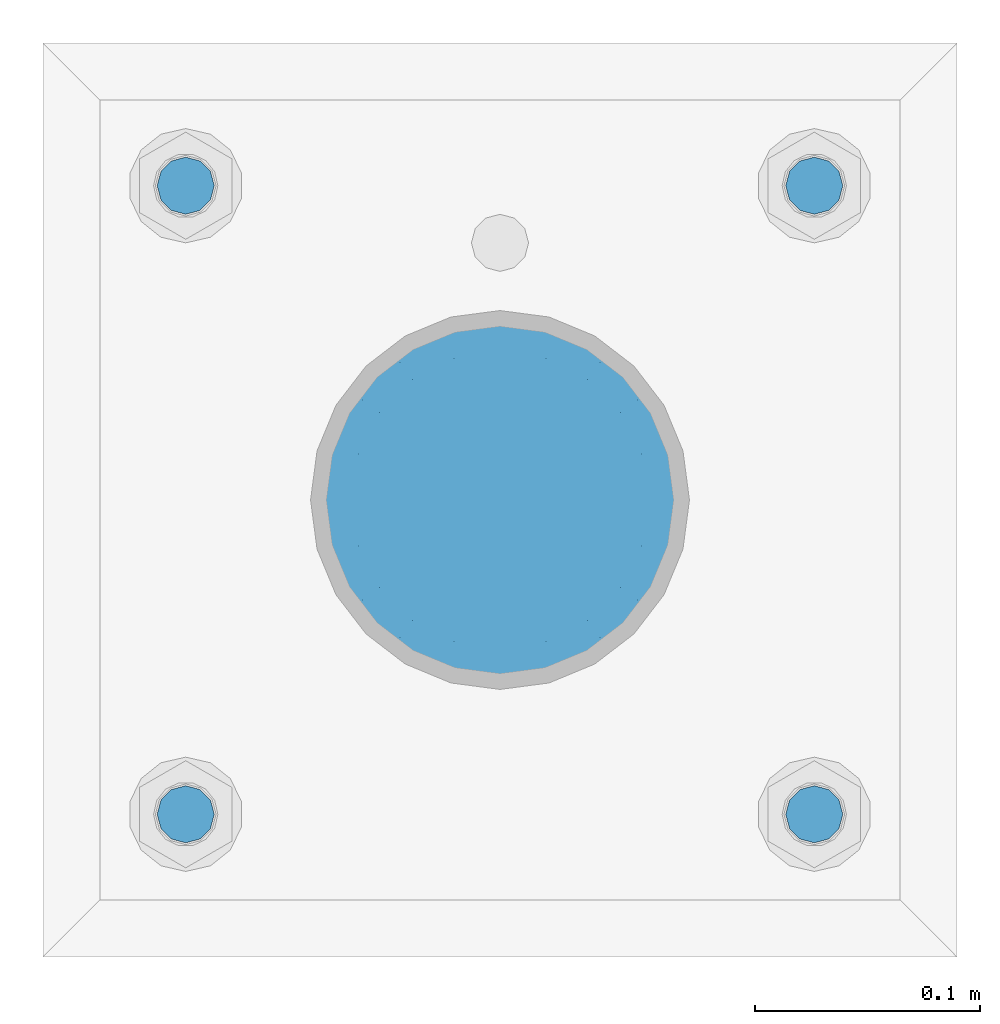
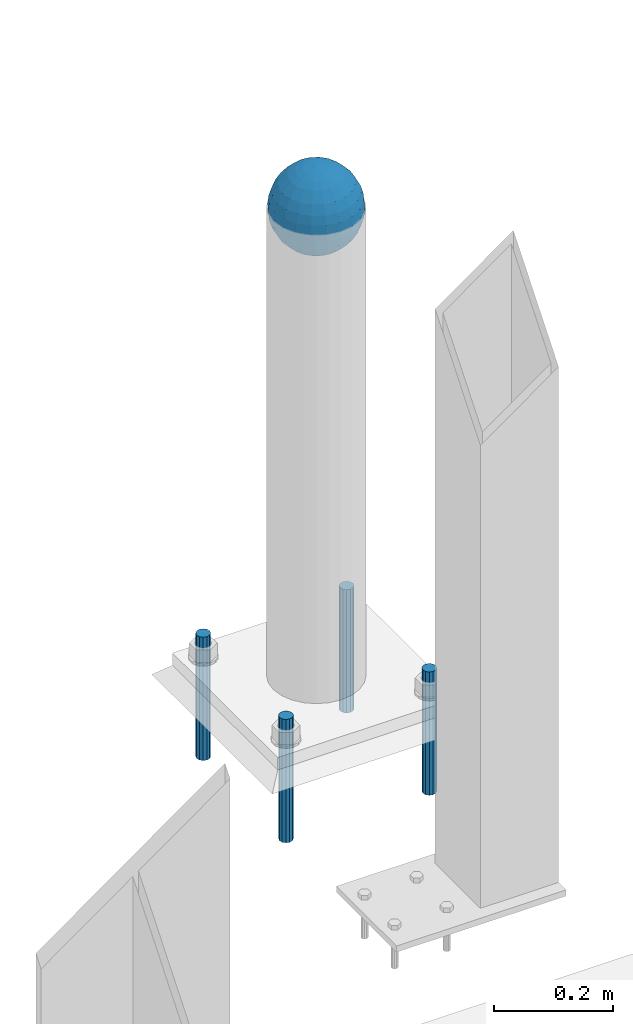
# One storey, part 1582 of 3843: 5 columns, 2 elements without a shape of their own.
"""IFC2X3 building model written with IfcOpenShell, lengths in millimetres."""

from ifc_helpers import new_model, si_unit, frame, origin_with_axes, place, context, subcontext, project, spatial, faceted_brep, material, type_object, element, aggregate, save


model = new_model("IFC2X3")

# Units and contexts
model_context = context("Model", 3, precision=1e-05, world=origin_with_axes())
body_context = subcontext(model_context, "Body", "Model", "MODEL_VIEW")
ifc_project = project(units=[si_unit("LENGTHUNIT", "METRE", prefix="MILLI"), si_unit("AREAUNIT", "SQUARE_METRE"), si_unit("VOLUMEUNIT", "CUBIC_METRE"), si_unit("MASSUNIT", "GRAM", prefix="KILO"), si_unit("TIMEUNIT", "SECOND"), si_unit("PLANEANGLEUNIT", "RADIAN"), si_unit("SOLIDANGLEUNIT", "STERADIAN"), si_unit("THERMODYNAMICTEMPERATUREUNIT", "DEGREE_CELSIUS"), si_unit("LUMINOUSINTENSITYUNIT", "LUMEN")], contexts=[model_context])

# Site, building, storey
site_placement = place(None, origin_with_axes())
site = spatial("IfcSite", under=ifc_project, at=site_placement, CompositionType="ELEMENT")
building_placement = place(site_placement, origin_with_axes())
building = spatial("IfcBuilding", under=site, at=building_placement, Name="Undefined", CompositionType="ELEMENT")
storey_placement = place(building_placement, origin_with_axes())
storey = spatial("IfcBuildingStorey", under=building, at=storey_placement, Name="Undefined", CompositionType="ELEMENT", Elevation=0.0)

# Assembly, column
assembly_1_placement = place(storey_placement, origin_with_axes())
assembly_1 = element("IfcElementAssembly", 1, at=assembly_1_placement, inside=storey, Name="CONC. FILL", AssemblyPlace="NOTDEFINED", PredefinedType="REINFORCEMENT_UNIT")
ifc_material_1 = material(Name="CONCRETE/1500")
column_type_1 = type_object("IfcColumnType", PredefinedType="NOTDEFINED")
column_1_placement = place(assembly_1_placement, frame((42849.8, 93129.1, 31411.8625), z_axis=(-1.0, 0.0, 0.0), x_axis=(0.0, 0.0, 1.0)))
column_1 = element("IfcColumn", 2, at=column_1_placement, type_object=column_type_1, material=ifc_material_1, Name="CONC. FILL", context=body_context, shape_type="Brep", body=[
    faceted_brep([(0.0, 0.0, 2.0), (0.0, -0.619999999995343, 1.89999999999964), (3.36549999999988, -7.1422259999963, 21.9814139999999), (3.36549999999988, 0.0, 23.1139999999996), (0.0, -1.17999999999302, 1.6200000000008), (3.36549999999988, -13.5910319999966, 18.6992260000006), (0.0, -1.61999999999534, 1.18000000000029), (3.36549999999988, -18.699225999997, 13.5910320000003), (0.0, -1.89999999999418, 0.6200000000008), (3.36549999999988, -21.9814139999944, 7.14222599999994), (0.0, -2.0, 0.0), (3.36549999999988, -23.1140000000014, 0.0), (0.0, -1.89999999999418, -0.6200000000008), (3.36549999999988, -21.9814139999944, -7.14222599999994), (0.0, -1.61999999999534, -1.18000000000029), (3.36549999999988, -18.699225999997, -13.5910320000003), (0.0, -1.17999999999302, -1.6200000000008), (3.36549999999988, -13.5910319999966, -18.6992260000006), (0.0, -0.619999999995343, -1.89999999999964), (3.36549999999988, -7.1422259999963, -21.9814139999999), (0.0, 0.0, -2.0), (3.36549999999988, 0.0, -23.1139999999996), (0.0, 0.619999999995343, -1.89999999999964), (3.36549999999988, 7.1422259999963, -21.9814139999999), (0.0, 1.17999999999302, -1.6200000000008), (3.36549999999988, 13.5910319999966, -18.6992260000006), (0.0, 1.61999999999534, -1.18000000000029), (3.36549999999988, 18.699225999997, -13.5910320000003), (0.0, 1.89999999999418, -0.6200000000008), (3.36549999999988, 21.9814139999944, -7.14222599999994), (0.0, 2.0, 0.0), (3.36549999999988, 23.1140000000014, 0.0), (0.0, 1.89999999999418, 0.6200000000008), (3.36549999999988, 21.9814139999944, 7.14222599999994), (0.0, 1.61999999999534, 1.18000000000029), (3.36549999999988, 18.699225999997, 13.5910320000003), (0.0, 1.17999999999302, 1.6200000000008), (3.36549999999988, 13.5910319999966, 18.6992260000006), (0.0, 0.619999999995343, 1.89999999999964), (3.36549999999988, 7.1422259999963, 21.9814139999999), (8.41374999999971, -11.1214661999984, 34.2282018000005), (8.41374999999971, 0.0, 35.9917999999998), (8.41374999999971, -21.1631784000056, 29.1173662000001), (8.41374999999971, -29.1173661999928, 21.1631784000001), (8.41374999999971, -34.2282017999969, 11.1214662000002), (8.41374999999971, -35.9918000000034, 0.0), (8.41374999999971, -34.2282017999969, -11.1214662000002), (8.41374999999971, -29.1173661999928, -21.1631784000001), (8.41374999999971, -21.1631784000056, -29.1173662000001), (8.41374999999971, -11.1214661999984, -34.2282018000005), (8.41374999999971, 0.0, -35.9917999999998), (8.41374999999971, 11.1214661999984, -34.2282018000005), (8.41374999999971, 21.1631784000056, -29.1173662000001), (8.41374999999971, 29.1173661999928, -21.1631784000001), (8.41374999999971, 34.2282017999969, -11.1214662000002), (8.41374999999971, 35.9918000000034, 0.0), (8.41374999999971, 34.2282017999969, 11.1214662000002), (8.41374999999971, 29.1173661999928, 21.1631784000001), (8.41374999999971, 21.1631784000056, 29.1173662000001), (8.41374999999971, 11.1214661999984, 34.2282018000005), (16.8274999999994, -15.3047700000025, 47.1030300000002), (16.8274999999994, 0.0, 49.5300000000007), (16.8274999999994, -29.1236400000053, 40.0697700000001), (16.8274999999994, -40.0697700000019, 29.1236399999998), (16.8274999999994, -47.1030299999984, 15.3047700000006), (16.8274999999994, -49.5299999999988, 0.0), (16.8274999999994, -47.1030299999984, -15.3047700000006), (16.8274999999994, -40.0697700000019, -29.1236399999998), (16.8274999999994, -29.1236400000053, -40.0697700000001), (16.8274999999994, -15.3047700000025, -47.1030300000002), (16.8274999999994, 0.0, -49.5300000000007), (16.8274999999994, 15.3047700000025, -47.1030300000002), (16.8274999999994, 29.1236400000053, -40.0697700000001), (16.8274999999994, 40.0697700000019, -29.1236399999998), (16.8274999999994, 47.1030299999984, -15.3047700000006), (16.8274999999994, 49.5299999999988, 0.0), (16.8274999999994, 47.1030299999984, 15.3047700000006), (16.8274999999994, 40.0697700000019, 29.1236399999998), (16.8274999999994, 29.1236400000053, 40.0697700000001), (16.8274999999994, 15.3047700000025, 47.1030300000002), (33.6549999999988, -20.4063599999936, 62.8040400000009), (33.6549999999988, 0.0, 66.0400000000009), (33.6549999999988, -38.831520000007, 53.4263599999995), (33.6549999999988, -53.4263599999977, 38.8315199999997), (33.6549999999988, -62.8040400000027, 20.4063600000009), (33.6549999999988, -66.0399999999936, 0.0), (33.6549999999988, -62.8040400000027, -20.4063600000009), (33.6549999999988, -53.4263599999977, -38.8315199999997), (33.6549999999988, -38.831520000007, -53.4263599999995), (33.6549999999988, -20.4063599999936, -62.8040400000009), (33.6549999999988, 0.0, -66.0400000000009), (33.6549999999988, 20.4063599999936, -62.8040400000009), (33.6549999999988, 38.831520000007, -53.4263599999995), (33.6549999999988, 53.4263599999977, -38.8315199999997), (33.6549999999988, 62.8040400000027, -20.4063600000009), (33.6549999999988, 66.0399999999936, 0.0), (33.6549999999988, 62.8040400000027, 20.4063600000009), (33.6549999999988, 53.4263599999977, 38.8315199999997), (33.6549999999988, 38.831520000007, 53.4263599999995), (33.6549999999988, 20.4063599999936, 62.8040400000009), (50.4824999999983, -23.3907901500061, 71.9891308499991), (50.4824999999983, 0.0, 75.6983500000006), (50.4824999999983, -44.5106298000028, 61.23996515), (50.4824999999983, -61.2399651500018, 44.5106297999992), (50.4824999999983, -71.9891308499937, 23.3907901500006), (50.4824999999983, -75.698350000006, 0.0), (50.4824999999983, -71.9891308499937, -23.3907901500006), (50.4824999999983, -61.2399651500018, -44.5106297999992), (50.4824999999983, -44.5106298000028, -61.23996515), (50.4824999999983, -23.3907901500061, -71.9891308499991), (50.4824999999983, 0.0, -75.6983500000006), (50.4824999999983, 23.3907901500061, -71.9891308499991), (50.4824999999983, 44.5106298000028, -61.23996515), (50.4824999999983, 61.2399651500018, -44.5106297999992), (50.4824999999983, 71.9891308499937, -23.3907901500006), (50.4824999999983, 75.698350000006, 0.0), (50.4824999999983, 71.9891308499937, 23.3907901500006), (50.4824999999983, 61.2399651500018, 44.5106297999992), (50.4824999999983, 44.5106298000028, 61.23996515), (50.4824999999983, 23.3907901500061, 71.9891308499991), (67.3099999999977, -24.9977910000016, 76.9349490000004), (67.3099999999977, 0.0, 80.8989999999994), (67.3099999999977, -47.5686120000028, 65.4472910000004), (67.3099999999977, -65.447291000004, 47.5686119999991), (67.3099999999977, -76.9349490000022, 24.9977909999998), (67.3099999999977, -80.8990000000049, 0.0), (67.3099999999977, -76.9349490000022, -24.9977909999998), (67.3099999999977, -65.447291000004, -47.5686119999991), (67.3099999999977, -47.5686120000028, -65.4472910000004), (67.3099999999977, -24.9977910000016, -76.9349490000004), (67.3099999999977, 0.0, -80.8989999999994), (67.3099999999977, 24.9977910000016, -76.9349490000004), (67.3099999999977, 47.5686120000028, -65.4472910000004), (67.3099999999977, 65.447291000004, -47.5686119999991), (67.3099999999977, 76.9349490000022, -24.9977909999998), (67.3099999999977, 80.8990000000049, 0.0), (67.3099999999977, 76.9349490000022, 24.9977909999998), (67.3099999999977, 65.447291000004, 47.5686119999991), (67.3099999999977, 47.5686120000028, 65.4472910000004), (67.3099999999977, 24.9977910000016, 76.9349490000004), (84.1374999999935, -25.5079499999993, 78.5050499999998), (84.1374999999935, 0.0, 82.5499999999993), (84.1374999999935, -48.5393999999942, 66.7829500000007), (84.1374999999935, -66.7829499999934, 48.5393999999997), (84.1374999999935, -78.505050000007, 25.5079499999993), (84.1374999999935, -82.5500000000029, 0.0), (84.1374999999935, -78.505050000007, -25.5079499999993), (84.1374999999935, -66.7829499999934, -48.5393999999997), (84.1374999999935, -48.5393999999942, -66.7829500000007), (84.1374999999935, -25.5079499999993, -78.5050499999998), (84.1374999999935, 0.0, -82.5499999999993), (84.1374999999935, 25.5079499999993, -78.5050499999998), (84.1374999999935, 48.5393999999942, -66.7829500000007), (84.1374999999935, 66.7829499999934, -48.5393999999997), (84.1374999999935, 78.505050000007, -25.5079499999993), (84.1374999999935, 82.5500000000029, 0.0), (84.1374999999935, 78.505050000007, 25.5079499999993), (84.1374999999935, 66.7829499999934, 48.5393999999997), (84.1374999999935, 48.5393999999942, 66.7829500000007), (84.1374999999935, 25.5079499999993, 78.5050499999998), (100.964999999993, -24.9977910000016, 76.9349490000004), (100.964999999993, 0.0, 80.8989999999994), (100.964999999993, -47.5686120000028, 65.4472910000004), (100.964999999993, -65.447291000004, 47.5686119999991), (100.964999999993, -76.9349490000022, 24.9977909999998), (100.964999999993, -80.8990000000049, 0.0), (100.964999999993, -76.9349490000022, -24.9977909999998), (100.964999999993, -65.447291000004, -47.5686119999991), (100.964999999993, -47.5686120000028, -65.4472910000004), (100.964999999993, -24.9977910000016, -76.9349490000004), (100.964999999993, 0.0, -80.8989999999994), (100.964999999993, 24.9977910000016, -76.9349490000004), (100.964999999993, 47.5686120000028, -65.4472910000004), (100.964999999993, 65.447291000004, -47.5686119999991), (100.964999999993, 76.9349490000022, -24.9977909999998), (100.964999999993, 80.8990000000049, 0.0), (100.964999999993, 76.9349490000022, 24.9977909999998), (100.964999999993, 65.447291000004, 47.5686119999991), (100.964999999993, 47.5686120000028, 65.4472910000004), (100.964999999993, 24.9977910000016, 76.9349490000004), (117.792499999992, -23.3907901500061, 71.9891308499991), (117.792499999992, 0.0, 75.6983500000006), (117.792499999992, -44.5106298000028, 61.23996515), (117.792499999992, -61.2399651500018, 44.5106297999992), (117.792499999992, -71.9891308499937, 23.3907901500006), (117.792499999992, -75.698350000006, 0.0), (117.792499999992, -71.9891308499937, -23.3907901500006), (117.792499999992, -61.2399651500018, -44.5106297999992), (117.792499999992, -44.5106298000028, -61.23996515), (117.792499999992, -23.3907901500061, -71.9891308499991), (117.792499999992, 0.0, -75.6983500000006), (117.792499999992, 23.3907901500061, -71.9891308499991), (117.792499999992, 44.5106298000028, -61.23996515), (117.792499999992, 61.2399651500018, -44.5106297999992), (117.792499999992, 71.9891308499937, -23.3907901500006), (117.792499999992, 75.698350000006, 0.0), (117.792499999992, 71.9891308499937, 23.3907901500006), (117.792499999992, 61.2399651500018, 44.5106297999992), (117.792499999992, 44.5106298000028, 61.23996515), (117.792499999992, 23.3907901500061, 71.9891308499991), (134.619999999992, -20.4063599999936, 62.8040400000009), (134.619999999992, 0.0, 66.0400000000009), (134.619999999992, -38.831520000007, 53.4263599999995), (134.619999999992, -53.4263599999977, 38.8315199999997), (134.619999999992, -62.8040400000027, 20.4063600000009), (134.619999999992, -66.0399999999936, 0.0), (134.619999999992, -62.8040400000027, -20.4063600000009), (134.619999999992, -53.4263599999977, -38.8315199999997), (134.619999999992, -38.831520000007, -53.4263599999995), (134.619999999992, -20.4063599999936, -62.8040400000009), (134.619999999992, 0.0, -66.0400000000009), (134.619999999992, 20.4063599999936, -62.8040400000009), (134.619999999992, 38.831520000007, -53.4263599999995), (134.619999999992, 53.4263599999977, -38.8315199999997), (134.619999999992, 62.8040400000027, -20.4063600000009), (134.619999999992, 66.0399999999936, 0.0), (134.619999999992, 62.8040400000027, 20.4063600000009), (134.619999999992, 53.4263599999977, 38.8315199999997), (134.619999999992, 38.831520000007, 53.4263599999995), (134.619999999992, 20.4063599999936, 62.8040400000009), (151.447499999991, -15.3047700000025, 47.1030300000002), (151.447499999991, 0.0, 49.5300000000007), (151.447499999991, -29.1236400000053, 40.0697700000001), (151.447499999991, -40.0697700000019, 29.1236399999998), (151.447499999991, -47.1030299999984, 15.3047700000006), (151.447499999991, -49.5299999999988, 0.0), (151.447499999991, -47.1030299999984, -15.3047700000006), (151.447499999991, -40.0697700000019, -29.1236399999998), (151.447499999991, -29.1236400000053, -40.0697700000001), (151.447499999991, -15.3047700000025, -47.1030300000002), (151.447499999991, 0.0, -49.5300000000007), (151.447499999991, 15.3047700000025, -47.1030300000002), (151.447499999991, 29.1236400000053, -40.0697700000001), (151.447499999991, 40.0697700000019, -29.1236399999998), (151.447499999991, 47.1030299999984, -15.3047700000006), (151.447499999991, 49.5299999999988, 0.0), (151.447499999991, 47.1030299999984, 15.3047700000006), (151.447499999991, 40.0697700000019, 29.1236399999998), (151.447499999991, 29.1236400000053, 40.0697700000001), (151.447499999991, 15.3047700000025, 47.1030300000002), (159.861249999991, -11.1214661999984, 34.2282018000005), (159.861249999991, 0.0, 35.9917999999998), (159.861249999991, -21.1631784000056, 29.1173662000001), (159.861249999991, -29.1173661999928, 21.1631784000001), (159.861249999991, -34.2282017999969, 11.1214662000002), (159.861249999991, -35.9918000000034, 0.0), (159.861249999991, -34.2282017999969, -11.1214662000002), (159.861249999991, -29.1173661999928, -21.1631784000001), (159.861249999991, -21.1631784000056, -29.1173662000001), (159.861249999991, -11.1214661999984, -34.2282018000005), (159.861249999991, 0.0, -35.9917999999998), (159.861249999991, 11.1214661999984, -34.2282018000005), (159.861249999991, 21.1631784000056, -29.1173662000001), (159.861249999991, 29.1173661999928, -21.1631784000001), (159.861249999991, 34.2282017999969, -11.1214662000002), (159.861249999991, 35.9918000000034, 0.0), (159.861249999991, 34.2282017999969, 11.1214662000002), (159.861249999991, 29.1173661999928, 21.1631784000001), (159.861249999991, 21.1631784000056, 29.1173662000001), (159.861249999991, 11.1214661999984, 34.2282018000005), (164.909499999991, -7.1422259999963, 21.9814139999999), (164.909499999991, 0.0, 23.1139999999996), (164.909499999991, -13.5910319999966, 18.6992260000006), (164.909499999991, -18.699225999997, 13.5910320000003), (164.909499999991, -21.9814139999944, 7.14222599999994), (164.909499999991, -23.1140000000014, 0.0), (164.909499999991, -21.9814139999944, -7.14222599999994), (164.909499999991, -18.699225999997, -13.5910320000003), (164.909499999991, -13.5910319999966, -18.6992260000006), (164.909499999991, -7.1422259999963, -21.9814139999999), (164.909499999991, 0.0, -23.1139999999996), (164.909499999991, 7.1422259999963, -21.9814139999999), (164.909499999991, 13.5910319999966, -18.6992260000006), (164.909499999991, 18.699225999997, -13.5910320000003), (164.909499999991, 21.9814139999944, -7.14222599999994), (164.909499999991, 23.1140000000014, 0.0), (164.909499999991, 21.9814139999944, 7.14222599999994), (164.909499999991, 18.699225999997, 13.5910320000003), (164.909499999991, 13.5910319999966, 18.6992260000006), (164.909499999991, 7.1422259999963, 21.9814139999999), (168.274999999991, -0.619999999995343, 1.89999999999964), (168.274999999991, 0.0, 2.0), (168.274999999991, -1.17999999999302, 1.6200000000008), (168.274999999991, -1.61999999999534, 1.18000000000029), (168.274999999991, -1.89999999999418, 0.6200000000008), (168.274999999991, -2.0, 0.0), (168.274999999991, -1.89999999999418, -0.6200000000008), (168.274999999991, -1.61999999999534, -1.18000000000029), (168.274999999991, -1.17999999999302, -1.6200000000008), (168.274999999991, -0.619999999995343, -1.89999999999964), (168.274999999991, 0.0, -2.0), (168.274999999991, 0.619999999995343, -1.89999999999964), (168.274999999991, 1.17999999999302, -1.6200000000008), (168.274999999991, 1.61999999999534, -1.18000000000029), (168.274999999991, 1.89999999999418, -0.6200000000008), (168.274999999991, 2.0, 0.0), (168.274999999991, 1.89999999999418, 0.6200000000008), (168.274999999991, 1.61999999999534, 1.18000000000029), (168.274999999991, 1.17999999999302, 1.6200000000008), (168.274999999991, 0.619999999995343, 1.89999999999964)], [[[0, 1, 2, 3]], [[1, 4, 5, 2]], [[4, 6, 7, 5]], [[6, 8, 9, 7]], [[8, 10, 11, 9]], [[10, 12, 13, 11]], [[12, 14, 15, 13]], [[14, 16, 17, 15]], [[16, 18, 19, 17]], [[18, 20, 21, 19]], [[20, 22, 23, 21]], [[22, 24, 25, 23]], [[24, 26, 27, 25]], [[26, 28, 29, 27]], [[28, 30, 31, 29]], [[30, 32, 33, 31]], [[32, 34, 35, 33]], [[34, 36, 37, 35]], [[36, 38, 39, 37]], [[38, 0, 3, 39]], [[38, 36, 34, 32, 30, 28, 26, 24, 22, 20, 18, 16, 14, 12, 10, 8, 6, 4, 1, 0]], [[3, 2, 40, 41]], [[2, 5, 42, 40]], [[5, 7, 43, 42]], [[7, 9, 44, 43]], [[9, 11, 45, 44]], [[11, 13, 46, 45]], [[13, 15, 47, 46]], [[15, 17, 48, 47]], [[17, 19, 49, 48]], [[19, 21, 50, 49]], [[21, 23, 51, 50]], [[23, 25, 52, 51]], [[25, 27, 53, 52]], [[27, 29, 54, 53]], [[29, 31, 55, 54]], [[31, 33, 56, 55]], [[33, 35, 57, 56]], [[35, 37, 58, 57]], [[37, 39, 59, 58]], [[39, 3, 41, 59]], [[41, 40, 60, 61]], [[40, 42, 62, 60]], [[42, 43, 63, 62]], [[43, 44, 64, 63]], [[44, 45, 65, 64]], [[45, 46, 66, 65]], [[46, 47, 67, 66]], [[47, 48, 68, 67]], [[48, 49, 69, 68]], [[49, 50, 70, 69]], [[50, 51, 71, 70]], [[51, 52, 72, 71]], [[52, 53, 73, 72]], [[53, 54, 74, 73]], [[54, 55, 75, 74]], [[55, 56, 76, 75]], [[56, 57, 77, 76]], [[57, 58, 78, 77]], [[58, 59, 79, 78]], [[59, 41, 61, 79]], [[61, 60, 80, 81]], [[60, 62, 82, 80]], [[62, 63, 83, 82]], [[63, 64, 84, 83]], [[64, 65, 85, 84]], [[65, 66, 86, 85]], [[66, 67, 87, 86]], [[67, 68, 88, 87]], [[68, 69, 89, 88]], [[69, 70, 90, 89]], [[70, 71, 91, 90]], [[71, 72, 92, 91]], [[72, 73, 93, 92]], [[73, 74, 94, 93]], [[74, 75, 95, 94]], [[75, 76, 96, 95]], [[76, 77, 97, 96]], [[77, 78, 98, 97]], [[78, 79, 99, 98]], [[79, 61, 81, 99]], [[81, 80, 100, 101]], [[80, 82, 102, 100]], [[82, 83, 103, 102]], [[83, 84, 104, 103]], [[84, 85, 105, 104]], [[85, 86, 106, 105]], [[86, 87, 107, 106]], [[87, 88, 108, 107]], [[88, 89, 109, 108]], [[89, 90, 110, 109]], [[90, 91, 111, 110]], [[91, 92, 112, 111]], [[92, 93, 113, 112]], [[93, 94, 114, 113]], [[94, 95, 115, 114]], [[95, 96, 116, 115]], [[96, 97, 117, 116]], [[97, 98, 118, 117]], [[98, 99, 119, 118]], [[99, 81, 101, 119]], [[101, 100, 120, 121]], [[100, 102, 122, 120]], [[102, 103, 123, 122]], [[103, 104, 124, 123]], [[104, 105, 125, 124]], [[105, 106, 126, 125]], [[106, 107, 127, 126]], [[107, 108, 128, 127]], [[108, 109, 129, 128]], [[109, 110, 130, 129]], [[110, 111, 131, 130]], [[111, 112, 132, 131]], [[112, 113, 133, 132]], [[113, 114, 134, 133]], [[114, 115, 135, 134]], [[115, 116, 136, 135]], [[116, 117, 137, 136]], [[117, 118, 138, 137]], [[118, 119, 139, 138]], [[119, 101, 121, 139]], [[121, 120, 140, 141]], [[120, 122, 142, 140]], [[122, 123, 143, 142]], [[123, 124, 144, 143]], [[124, 125, 145, 144]], [[125, 126, 146, 145]], [[126, 127, 147, 146]], [[127, 128, 148, 147]], [[128, 129, 149, 148]], [[129, 130, 150, 149]], [[130, 131, 151, 150]], [[131, 132, 152, 151]], [[132, 133, 153, 152]], [[133, 134, 154, 153]], [[134, 135, 155, 154]], [[135, 136, 156, 155]], [[136, 137, 157, 156]], [[137, 138, 158, 157]], [[138, 139, 159, 158]], [[139, 121, 141, 159]], [[141, 140, 160, 161]], [[140, 142, 162, 160]], [[142, 143, 163, 162]], [[143, 144, 164, 163]], [[144, 145, 165, 164]], [[145, 146, 166, 165]], [[146, 147, 167, 166]], [[147, 148, 168, 167]], [[148, 149, 169, 168]], [[149, 150, 170, 169]], [[150, 151, 171, 170]], [[151, 152, 172, 171]], [[152, 153, 173, 172]], [[153, 154, 174, 173]], [[154, 155, 175, 174]], [[155, 156, 176, 175]], [[156, 157, 177, 176]], [[157, 158, 178, 177]], [[158, 159, 179, 178]], [[159, 141, 161, 179]], [[161, 160, 180, 181]], [[160, 162, 182, 180]], [[162, 163, 183, 182]], [[163, 164, 184, 183]], [[164, 165, 185, 184]], [[165, 166, 186, 185]], [[166, 167, 187, 186]], [[167, 168, 188, 187]], [[168, 169, 189, 188]], [[169, 170, 190, 189]], [[170, 171, 191, 190]], [[171, 172, 192, 191]], [[172, 173, 193, 192]], [[173, 174, 194, 193]], [[174, 175, 195, 194]], [[175, 176, 196, 195]], [[176, 177, 197, 196]], [[177, 178, 198, 197]], [[178, 179, 199, 198]], [[179, 161, 181, 199]], [[181, 180, 200, 201]], [[180, 182, 202, 200]], [[182, 183, 203, 202]], [[183, 184, 204, 203]], [[184, 185, 205, 204]], [[185, 186, 206, 205]], [[186, 187, 207, 206]], [[187, 188, 208, 207]], [[188, 189, 209, 208]], [[189, 190, 210, 209]], [[190, 191, 211, 210]], [[191, 192, 212, 211]], [[192, 193, 213, 212]], [[193, 194, 214, 213]], [[194, 195, 215, 214]], [[195, 196, 216, 215]], [[196, 197, 217, 216]], [[197, 198, 218, 217]], [[198, 199, 219, 218]], [[199, 181, 201, 219]], [[201, 200, 220, 221]], [[200, 202, 222, 220]], [[202, 203, 223, 222]], [[203, 204, 224, 223]], [[204, 205, 225, 224]], [[205, 206, 226, 225]], [[206, 207, 227, 226]], [[207, 208, 228, 227]], [[208, 209, 229, 228]], [[209, 210, 230, 229]], [[210, 211, 231, 230]], [[211, 212, 232, 231]], [[212, 213, 233, 232]], [[213, 214, 234, 233]], [[214, 215, 235, 234]], [[215, 216, 236, 235]], [[216, 217, 237, 236]], [[217, 218, 238, 237]], [[218, 219, 239, 238]], [[219, 201, 221, 239]], [[221, 220, 240, 241]], [[220, 222, 242, 240]], [[222, 223, 243, 242]], [[223, 224, 244, 243]], [[224, 225, 245, 244]], [[225, 226, 246, 245]], [[226, 227, 247, 246]], [[227, 228, 248, 247]], [[228, 229, 249, 248]], [[229, 230, 250, 249]], [[230, 231, 251, 250]], [[231, 232, 252, 251]], [[232, 233, 253, 252]], [[233, 234, 254, 253]], [[234, 235, 255, 254]], [[235, 236, 256, 255]], [[236, 237, 257, 256]], [[237, 238, 258, 257]], [[238, 239, 259, 258]], [[239, 221, 241, 259]], [[241, 240, 260, 261]], [[240, 242, 262, 260]], [[242, 243, 263, 262]], [[243, 244, 264, 263]], [[244, 245, 265, 264]], [[245, 246, 266, 265]], [[246, 247, 267, 266]], [[247, 248, 268, 267]], [[248, 249, 269, 268]], [[249, 250, 270, 269]], [[250, 251, 271, 270]], [[251, 252, 272, 271]], [[252, 253, 273, 272]], [[253, 254, 274, 273]], [[254, 255, 275, 274]], [[255, 256, 276, 275]], [[256, 257, 277, 276]], [[257, 258, 278, 277]], [[258, 259, 279, 278]], [[259, 241, 261, 279]], [[261, 260, 280, 281]], [[260, 262, 282, 280]], [[262, 263, 283, 282]], [[263, 264, 284, 283]], [[264, 265, 285, 284]], [[265, 266, 286, 285]], [[266, 267, 287, 286]], [[267, 268, 288, 287]], [[268, 269, 289, 288]], [[269, 270, 290, 289]], [[270, 271, 291, 290]], [[271, 272, 292, 291]], [[272, 273, 293, 292]], [[273, 274, 294, 293]], [[274, 275, 295, 294]], [[275, 276, 296, 295]], [[276, 277, 297, 296]], [[277, 278, 298, 297]], [[278, 279, 299, 298]], [[279, 261, 281, 299]], [[282, 283, 284, 285, 286, 287, 288, 289, 290, 291, 292, 293, 294, 295, 296, 297, 298, 299, 281, 280]]]),
])
aggregate(assembly_1, [column_1])

# Assembly, columns
assembly_2_placement = place(storey_placement, origin_with_axes())
assembly_2 = element("IfcElementAssembly", 3, at=assembly_2_placement, inside=storey, Name="TEMPLATE", AssemblyPlace="NOTDEFINED", PredefinedType="RIGID_FRAME")
ifc_material_2 = material(Name="STEEL/316 SS")
column_type_2 = type_object("IfcColumnType", PredefinedType="NOTDEFINED")
column_2_placement = place(assembly_2_placement, frame((42989.5, 92989.4, 30581.6), z_axis=(1.0, 0.0, 0.0), x_axis=(0.0, 0.0, -1.0)))
column_2 = element("IfcColumn", 4, at=column_2_placement, type_object=column_type_2, material=ifc_material_2, Name="ANCHOR_ROD", context=body_context, shape_type="Brep", body=[
    faceted_brep([(0.0, -12.6999999999971, 0.0), (0.0, -10.9985226280696, -6.34999999999854), (253.999, -10.9985226280696, -6.34999999999854), (253.999, -12.6999999999971, 0.0), (0.0, -6.35000000000582, -10.9985226280623), (253.999, -6.35000000000582, -10.9985226280623), (0.0, 0.0, -12.6999999999971), (253.999, 0.0, -12.6999999999971), (0.0, 6.35000000000582, -10.9985226280623), (253.999, 6.35000000000582, -10.9985226280623), (0.0, 10.9985226280696, -6.34999999999854), (253.999, 10.9985226280696, -6.34999999999854), (0.0, 12.6999999999971, 0.0), (253.999, 12.6999999999971, 0.0), (0.0, 10.9985226280696, 6.34999999999854), (253.999, 10.9985226280696, 6.34999999999854), (0.0, 6.35000000000582, 10.9985226280623), (253.999, 6.35000000000582, 10.9985226280623), (0.0, 0.0, 12.6999999999971), (253.999, 0.0, 12.6999999999971), (0.0, -6.35000000000582, 10.9985226280623), (253.999, -6.35000000000582, 10.9985226280623), (0.0, -10.9985226280696, 6.34999999999854), (253.999, -10.9985226280696, 6.34999999999854)], [[[0, 1, 2, 3]], [[1, 4, 5, 2]], [[4, 6, 7, 5]], [[6, 8, 9, 7]], [[8, 10, 11, 9]], [[10, 12, 13, 11]], [[12, 14, 15, 13]], [[14, 16, 17, 15]], [[16, 18, 19, 17]], [[18, 20, 21, 19]], [[20, 22, 23, 21]], [[22, 0, 3, 23]], [[5, 7, 9, 11, 13, 15, 17, 19, 21, 23, 3, 2]], [[22, 20, 18, 16, 14, 12, 10, 8, 6, 4, 1, 0]]]),
])
column_3_placement = place(assembly_2_placement, frame((42989.5, 93268.8, 30581.6), z_axis=(-1.0, 0.0, 0.0), x_axis=(0.0, 0.0, -1.0)))
column_3 = element("IfcColumn", 5, at=column_3_placement, type_object=column_type_2, material=ifc_material_2, Name="ANCHOR_ROD", context=body_context, shape_type="Brep", body=[
    faceted_brep([(0.0, -12.6999999999971, 0.0), (0.0, -10.9985226280696, -6.34999999999854), (253.999, -10.9985226280696, -6.34999999999854), (253.999, -12.6999999999971, 0.0), (0.0, -6.35000000000582, -10.9985226280623), (253.999, -6.35000000000582, -10.9985226280623), (0.0, 0.0, -12.6999999999971), (253.999, 0.0, -12.6999999999971), (0.0, 6.35000000000582, -10.9985226280623), (253.999, 6.35000000000582, -10.9985226280623), (0.0, 10.9985226280696, -6.34999999999854), (253.999, 10.9985226280696, -6.34999999999854), (0.0, 12.6999999999971, 0.0), (253.999, 12.6999999999971, 0.0), (0.0, 10.9985226280696, 6.34999999999854), (253.999, 10.9985226280696, 6.34999999999854), (0.0, 6.35000000000582, 10.9985226280623), (253.999, 6.35000000000582, 10.9985226280623), (0.0, 0.0, 12.6999999999971), (253.999, 0.0, 12.6999999999971), (0.0, -6.35000000000582, 10.9985226280623), (253.999, -6.35000000000582, 10.9985226280623), (0.0, -10.9985226280696, 6.34999999999854), (253.999, -10.9985226280696, 6.34999999999854)], [[[0, 1, 2, 3]], [[1, 4, 5, 2]], [[4, 6, 7, 5]], [[6, 8, 9, 7]], [[8, 10, 11, 9]], [[10, 12, 13, 11]], [[12, 14, 15, 13]], [[14, 16, 17, 15]], [[16, 18, 19, 17]], [[18, 20, 21, 19]], [[20, 22, 23, 21]], [[22, 0, 3, 23]], [[5, 7, 9, 11, 13, 15, 17, 19, 21, 23, 3, 2]], [[22, 20, 18, 16, 14, 12, 10, 8, 6, 4, 1, 0]]]),
])
column_4_placement = place(assembly_2_placement, frame((42710.1, 92989.4, 30581.6), z_axis=(1.0, 0.0, 0.0), x_axis=(0.0, 0.0, -1.0)))
column_4 = element("IfcColumn", 6, at=column_4_placement, type_object=column_type_2, material=ifc_material_2, Name="ANCHOR_ROD", context=body_context, shape_type="Brep", body=[
    faceted_brep([(0.0, -12.6999999999971, 0.0), (0.0, -10.9985226280696, -6.34999999999854), (253.999, -10.9985226280696, -6.34999999999854), (253.999, -12.6999999999971, 0.0), (0.0, -6.35000000000582, -10.9985226280623), (253.999, -6.35000000000582, -10.9985226280623), (0.0, 0.0, -12.6999999999971), (253.999, 0.0, -12.6999999999971), (0.0, 6.35000000000582, -10.9985226280623), (253.999, 6.35000000000582, -10.9985226280623), (0.0, 10.9985226280696, -6.34999999999854), (253.999, 10.9985226280696, -6.34999999999854), (0.0, 12.6999999999971, 0.0), (253.999, 12.6999999999971, 0.0), (0.0, 10.9985226280696, 6.34999999999854), (253.999, 10.9985226280696, 6.34999999999854), (0.0, 6.35000000000582, 10.9985226280623), (253.999, 6.35000000000582, 10.9985226280623), (0.0, 0.0, 12.6999999999971), (253.999, 0.0, 12.6999999999971), (0.0, -6.35000000000582, 10.9985226280623), (253.999, -6.35000000000582, 10.9985226280623), (0.0, -10.9985226280696, 6.34999999999854), (253.999, -10.9985226280696, 6.34999999999854)], [[[0, 1, 2, 3]], [[1, 4, 5, 2]], [[4, 6, 7, 5]], [[6, 8, 9, 7]], [[8, 10, 11, 9]], [[10, 12, 13, 11]], [[12, 14, 15, 13]], [[14, 16, 17, 15]], [[16, 18, 19, 17]], [[18, 20, 21, 19]], [[20, 22, 23, 21]], [[22, 0, 3, 23]], [[5, 7, 9, 11, 13, 15, 17, 19, 21, 23, 3, 2]], [[22, 20, 18, 16, 14, 12, 10, 8, 6, 4, 1, 0]]]),
])
column_5_placement = place(assembly_2_placement, frame((42710.1, 93268.8, 30581.6), z_axis=(-1.0, 0.0, 0.0), x_axis=(0.0, 0.0, -1.0)))
column_5 = element("IfcColumn", 7, at=column_5_placement, type_object=column_type_2, material=ifc_material_2, Name="ANCHOR_ROD", context=body_context, shape_type="Brep", body=[
    faceted_brep([(0.0, -12.6999999999971, 0.0), (0.0, -10.9985226280696, -6.34999999999854), (253.999, -10.9985226280696, -6.34999999999854), (253.999, -12.6999999999971, 0.0), (0.0, -6.35000000000582, -10.9985226280623), (253.999, -6.35000000000582, -10.9985226280623), (0.0, 0.0, -12.6999999999971), (253.999, 0.0, -12.6999999999971), (0.0, 6.35000000000582, -10.9985226280623), (253.999, 6.35000000000582, -10.9985226280623), (0.0, 10.9985226280696, -6.34999999999854), (253.999, 10.9985226280696, -6.34999999999854), (0.0, 12.6999999999971, 0.0), (253.999, 12.6999999999971, 0.0), (0.0, 10.9985226280696, 6.34999999999854), (253.999, 10.9985226280696, 6.34999999999854), (0.0, 6.35000000000582, 10.9985226280623), (253.999, 6.35000000000582, 10.9985226280623), (0.0, 0.0, 12.6999999999971), (253.999, 0.0, 12.6999999999971), (0.0, -6.35000000000582, 10.9985226280623), (253.999, -6.35000000000582, 10.9985226280623), (0.0, -10.9985226280696, 6.34999999999854), (253.999, -10.9985226280696, 6.34999999999854)], [[[0, 1, 2, 3]], [[1, 4, 5, 2]], [[4, 6, 7, 5]], [[6, 8, 9, 7]], [[8, 10, 11, 9]], [[10, 12, 13, 11]], [[12, 14, 15, 13]], [[14, 16, 17, 15]], [[16, 18, 19, 17]], [[18, 20, 21, 19]], [[20, 22, 23, 21]], [[22, 0, 3, 23]], [[5, 7, 9, 11, 13, 15, 17, 19, 21, 23, 3, 2]], [[22, 20, 18, 16, 14, 12, 10, 8, 6, 4, 1, 0]]]),
])
aggregate(assembly_2, [column_2, column_3, column_4, column_5])

save(model, "model.ifc")
